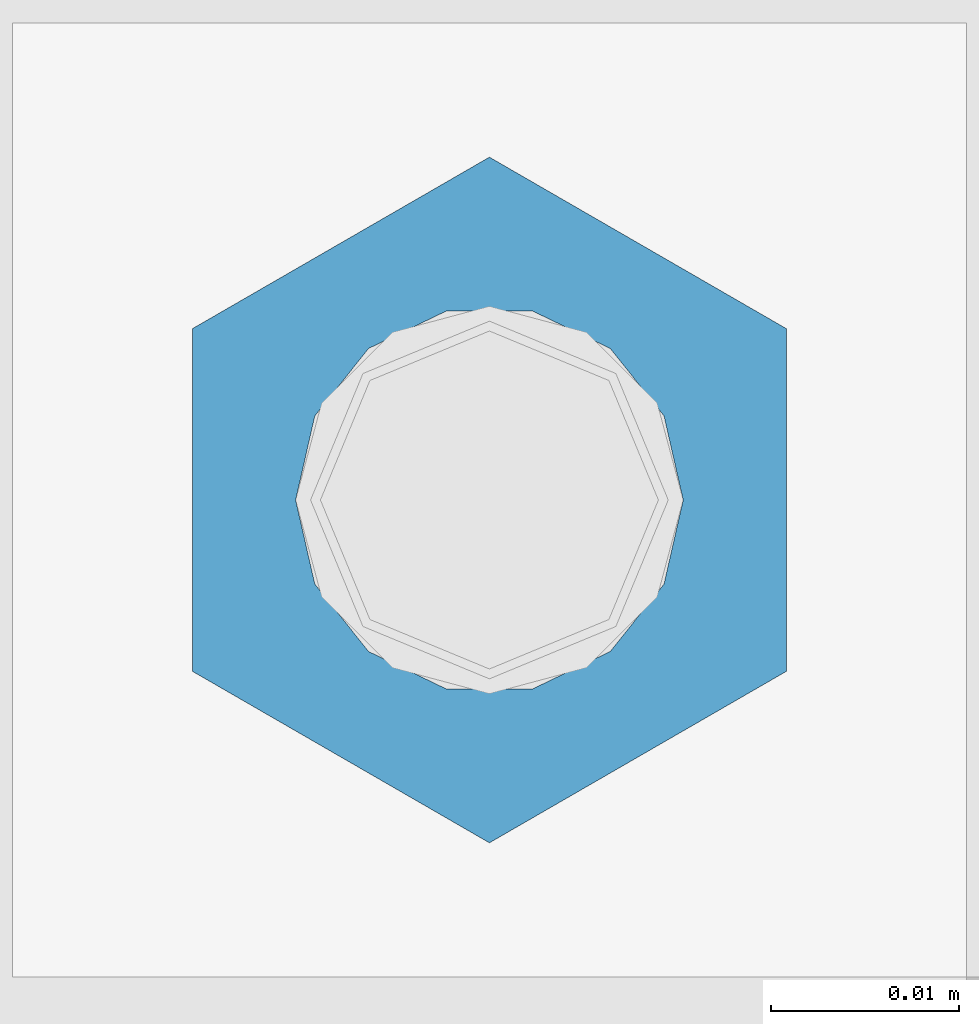
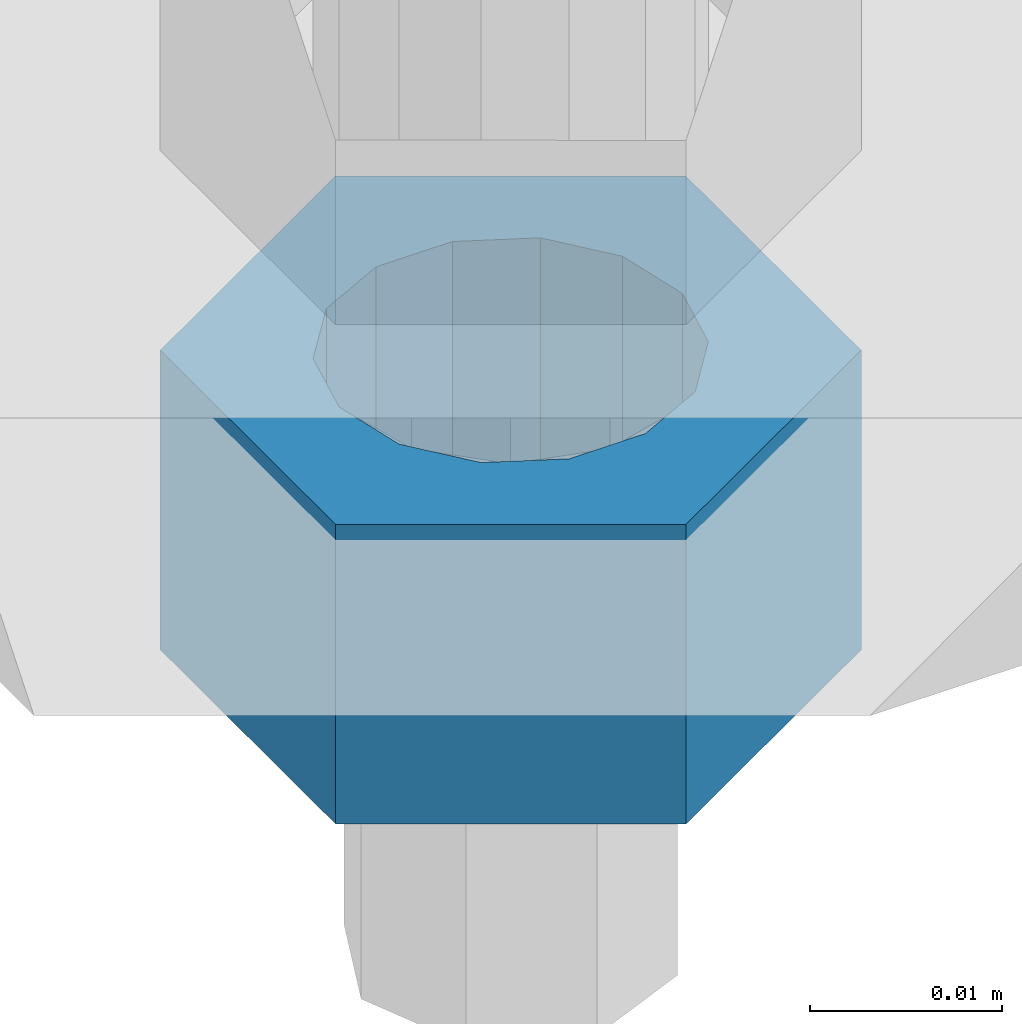
# One storey, part 1681 of 3843: 1 column, 1 element without a shape of its own.
"""IFC2X3 building model written with IfcOpenShell, lengths in millimetres."""

from ifc_helpers import new_model, si_unit, frame, origin_with_axes, place, context, subcontext, project, spatial, faceted_brep, material, type_object, element, aggregate, save


model = new_model("IFC2X3")

# Units and contexts
model_context = context("Model", 3, precision=1e-05, world=origin_with_axes())
body_context = subcontext(model_context, "Body", "Model", "MODEL_VIEW")
ifc_project = project(units=[si_unit("LENGTHUNIT", "METRE", prefix="MILLI"), si_unit("AREAUNIT", "SQUARE_METRE"), si_unit("VOLUMEUNIT", "CUBIC_METRE"), si_unit("MASSUNIT", "GRAM", prefix="KILO"), si_unit("TIMEUNIT", "SECOND"), si_unit("PLANEANGLEUNIT", "RADIAN"), si_unit("SOLIDANGLEUNIT", "STERADIAN"), si_unit("THERMODYNAMICTEMPERATUREUNIT", "DEGREE_CELSIUS"), si_unit("LUMINOUSINTENSITYUNIT", "LUMEN")], contexts=[model_context])

# Site, building, storey
site_placement = place(None, origin_with_axes())
site = spatial("IfcSite", under=ifc_project, at=site_placement, CompositionType="ELEMENT")
building_placement = place(site_placement, origin_with_axes())
building = spatial("IfcBuilding", under=site, at=building_placement, Name="Undefined", CompositionType="ELEMENT")
storey_placement = place(building_placement, origin_with_axes())
storey = spatial("IfcBuildingStorey", under=building, at=storey_placement, Name="Undefined", CompositionType="ELEMENT", Elevation=0.0)

# Assembly, column
assembly_placement = place(storey_placement, origin_with_axes())
assembly = element("IfcElementAssembly", 1, at=assembly_placement, inside=storey, Name="TEMPLATE", AssemblyPlace="NOTDEFINED", PredefinedType="RIGID_FRAME")
ifc_material = material(Name="STEEL/A36")
column_type = type_object("IfcColumnType", Name="3/4_HEAVY_HEX_NUT", PredefinedType="NOTDEFINED")
column_placement = place(assembly_placement, frame((38744.525, 50634.9, 29756.1), z_axis=(-1.0, 0.0, 0.0), x_axis=(0.0, 0.0, -1.0)))
column = element("IfcColumn", 2, at=column_placement, type_object=column_type, material=ifc_material, Name="NUT", ObjectType="3/4_HEAVY_HEX_NUT", context=body_context, shape_type="Brep", body=[
    faceted_brep([(0.0, -18.2600002288818, 0.0), (0.0, -9.13000011444092, -15.8100004196167), (19.0500000000029, -9.13000011444092, -15.8100004196167), (19.0500000000029, -18.2600002288818, 0.0), (0.0, 9.13000011444092, -15.8100004196167), (19.0500000000029, 9.13000011444092, -15.8100004196167), (0.0, 18.2600002288818, 0.0), (19.0500000000029, 18.2600002288818, 0.0), (0.0, 9.13000011444092, 15.8100004196167), (19.0500000000029, 9.13000011444092, 15.8100004196167), (0.0, -9.13000011444092, 15.8100004196167), (19.0500000000029, -9.13000011444092, 15.8100004196167), (0.0, 0.0, 10.3199996948242), (0.0, 4.47768005527905, 9.29799844179797), (19.0500000000029, 4.47768005527905, 9.29799844179797), (19.0500000000029, 0.0, 10.3199996948242), (0.0, 8.06850066047627, 6.43441456490837), (19.0500000000029, 8.06850066047627, 6.43441456490837), (0.0, 10.0612557561908, 2.2964159705225), (19.0500000000029, 10.0612557561908, 2.2964159705225), (0.0, 10.0612557561908, -2.2964159705225), (19.0500000000029, 10.0612557561908, -2.2964159705225), (0.0, 8.06850066047627, -6.43441456490837), (19.0500000000029, 8.06850066047627, -6.43441456490837), (0.0, 4.47768005527905, -9.29799844179797), (19.0500000000029, 4.47768005527905, -9.29799844179797), (0.0, 0.0, -10.3199996948242), (19.0500000000029, 0.0, -10.3199996948242), (0.0, -4.47768005527905, -9.29799844179797), (19.0500000000029, -4.47768005527905, -9.29799844179797), (0.0, -8.06850066047627, -6.43441456490837), (19.0500000000029, -8.06850066047627, -6.43441456490837), (0.0, -10.0612557561908, -2.2964159705225), (19.0500000000029, -10.0612557561908, -2.2964159705225), (0.0, -10.0612557561908, 2.2964159705225), (19.0500000000029, -10.0612557561908, 2.2964159705225), (0.0, -8.06850066047627, 6.43441456490837), (19.0500000000029, -8.06850066047627, 6.43441456490837), (0.0, -4.47768005527905, 9.29799844179797), (19.0500000000029, -4.47768005527905, 9.29799844179797)], [[[0, 1, 2, 3]], [[1, 4, 5, 2]], [[4, 6, 7, 5]], [[6, 8, 9, 7]], [[8, 10, 11, 9]], [[10, 0, 3, 11]], [[12, 13, 14, 15]], [[13, 16, 17, 14]], [[16, 18, 19, 17]], [[18, 20, 21, 19]], [[20, 22, 23, 21]], [[22, 24, 25, 23]], [[24, 26, 27, 25]], [[26, 28, 29, 27]], [[28, 30, 31, 29]], [[30, 32, 33, 31]], [[32, 34, 35, 33]], [[34, 36, 37, 35]], [[36, 38, 39, 37]], [[38, 12, 15, 39]], [[5, 7, 9, 11, 3, 2], [17, 19, 21, 23, 25, 27, 29, 31, 33, 35, 37, 39, 15, 14]], [[10, 8, 6, 4, 1, 0], [38, 36, 34, 32, 30, 28, 26, 24, 22, 20, 18, 16, 13, 12]]]),
])
aggregate(assembly, [column])

save(model, "model.ifc")
